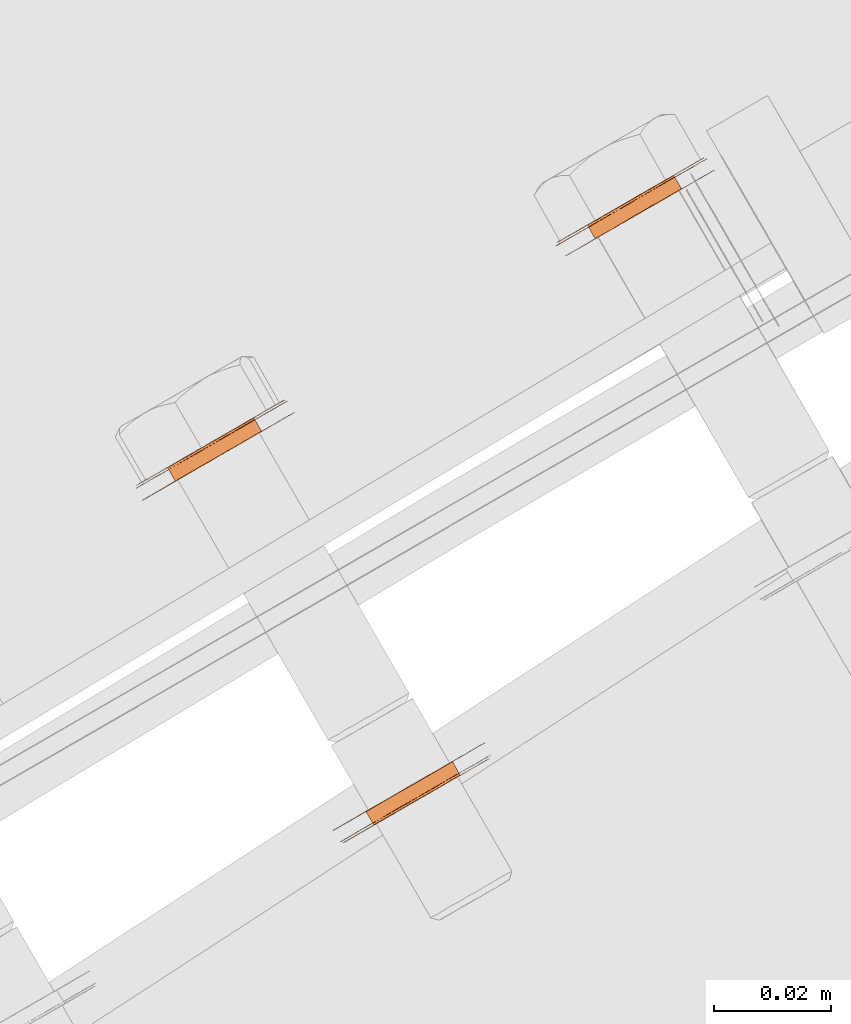
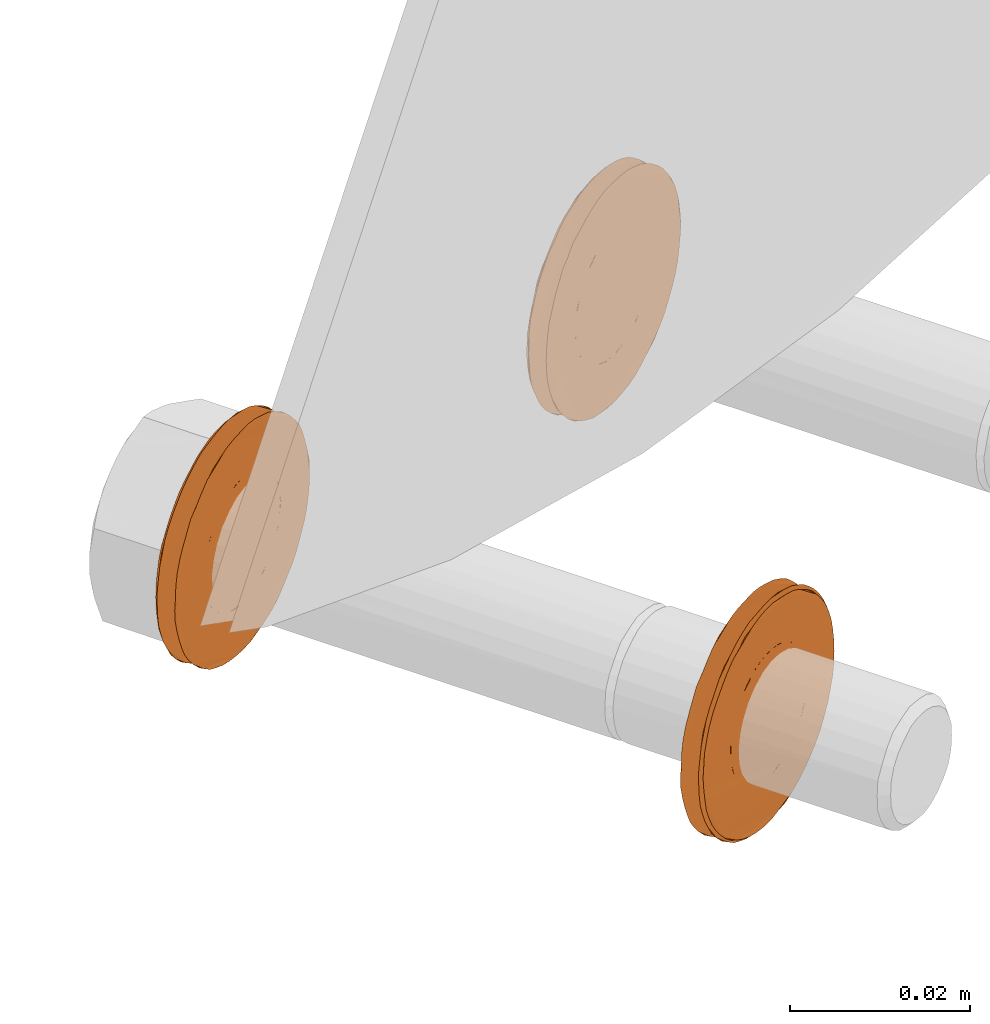
# One storey, part 113 of 126: 3 proxies.
"""IFC2X3 building model written with IfcOpenShell, lengths in millimetres."""

from ifc_helpers import new_model, si_unit, origin, origin_with_axes, place, context, project, spatial, faceted_brep, material, element, save


model = new_model("IFC2X3")

# Units and contexts
context_of_model_1 = context(None, 3, precision=0.1, world=origin())
context_of_model_2 = context(None, 3, precision=0.1, world=origin())
ifc_project = project(units=[si_unit("LENGTHUNIT", "METRE", prefix="MILLI"), si_unit("AREAUNIT", "SQUARE_METRE", prefix="CENTI"), si_unit("VOLUMEUNIT", "CUBIC_METRE", prefix="CENTI"), si_unit("MASSUNIT", "GRAM", prefix="KILO")], contexts=[context_of_model_1, context_of_model_2])

# Site, building, storey
site_placement = place(None, origin_with_axes())
site = spatial("IfcSite", under=ifc_project, at=site_placement, CompositionType="ELEMENT")
building_placement = place(site_placement, origin_with_axes())
building = spatial("IfcBuilding", under=site, at=building_placement, CompositionType="ELEMENT")
storey_placement = place(building_placement, origin_with_axes())
storey = spatial("IfcBuildingStorey", under=building, at=storey_placement, CompositionType="ELEMENT")

# Proxies
ifc_material = material(Name="STAHL")
proxy_1_placement = place(storey_placement, origin_with_axes())
element("IfcBuildingElementProxy", 1, at=proxy_1_placement, inside=storey, material=ifc_material, Name="profile", context=context_of_model_2, shape_type="Brep", body=[
    faceted_brep([(3949.6, 14948.2, 476.4), (3950.9, 14945.9, 476.4), (3949.9, 14945.3, 476.6), (3948.5, 14947.6, 476.6), (3946.7, 14946.5, 459.7), (3945.7, 14946.0, 460.1), (3947.1, 14943.6, 460.1), (3948.1, 14944.2, 459.7), (3944.7, 14945.4, 460.5), (3946.1, 14943.1, 460.5), (3943.8, 14944.9, 461.2), (3945.2, 14942.6, 461.2), (3943.0, 14944.4, 462.0), (3944.4, 14942.1, 462.0), (3942.3, 14944.0, 462.9), (3943.7, 14941.7, 462.9), (3941.8, 14943.7, 463.9), (3943.1, 14941.3, 463.9), (3941.3, 14943.4, 465.0), (3942.6, 14941.1, 465.0), (3941.0, 14943.2, 466.1), (3942.3, 14940.9, 466.1), (3940.8, 14943.1, 467.3), (3942.2, 14940.8, 467.3), (3940.8, 14943.1, 468.5), (3942.1, 14940.8, 468.5), (3940.9, 14943.2, 469.7), (3942.3, 14940.9, 469.7), (3941.2, 14943.4, 470.9), (3942.6, 14941.0, 470.9), (3941.6, 14943.6, 472.0), (3943.0, 14941.3, 472.0), (3942.2, 14943.9, 473.0), (3943.5, 14941.6, 473.0), (3942.9, 14944.3, 474.0), (3944.2, 14942.0, 474.0), (3943.6, 14944.8, 474.8), (3945.0, 14942.4, 474.8), (3944.5, 14945.3, 475.5), (3945.9, 14942.9, 475.5), (3945.5, 14945.8, 476.0), (3946.8, 14943.5, 476.0), (3946.5, 14946.4, 476.3), (3947.8, 14944.1, 476.3), (3947.5, 14947.0, 476.5), (3948.8, 14944.7, 476.5), (3936.5, 14937.5, 467.9), (3936.6, 14937.6, 469.4), (3936.8, 14937.7, 471.0), (3937.1, 14937.9, 472.5), (3937.6, 14938.1, 474.0), (3938.2, 14938.5, 475.4), (3938.9, 14938.9, 476.7), (3939.7, 14939.4, 478.0), (3940.7, 14939.9, 479.1), (3941.7, 14940.6, 480.1), (3940.6, 14942.5, 480.1), (3939.5, 14941.9, 479.1), (3938.6, 14941.4, 478.0), (3937.7, 14940.9, 476.7), (3937.0, 14940.5, 475.4), (3936.4, 14940.1, 474.0), (3935.9, 14939.9, 472.5), (3935.6, 14939.7, 471.0), (3935.4, 14939.6, 469.4), (3935.4, 14939.5, 467.9), (3935.4, 14939.6, 466.3), (3935.7, 14939.7, 464.8), (3936.0, 14939.9, 463.2), (3936.6, 14940.2, 461.8), (3937.2, 14940.6, 460.4), (3937.9, 14941.0, 459.1), (3938.8, 14941.5, 457.9), (3939.8, 14942.1, 456.8), (3940.9, 14942.7, 455.8), (3942.0, 14943.4, 455.0), (3943.2, 14944.1, 454.3), (3944.5, 14944.8, 453.7), (3945.8, 14945.6, 453.4), (3947.2, 14946.3, 453.1), (3948.5, 14947.1, 453.1), (3949.9, 14947.9, 453.2), (3951.2, 14948.7, 453.4), (3952.5, 14949.4, 453.9), (3953.8, 14950.2, 454.4), (3955.0, 14950.9, 455.2), (3956.1, 14951.5, 456.1), (3957.2, 14952.1, 457.1), (3958.1, 14952.7, 458.2), (3959.0, 14953.2, 459.4), (3959.7, 14953.6, 460.7), (3960.3, 14953.9, 462.1), (3960.8, 14954.2, 463.6), (3961.1, 14954.4, 465.1), (3961.3, 14954.5, 466.7), (3961.3, 14954.5, 468.3), (3961.2, 14954.5, 469.8), (3961.0, 14954.3, 471.4), (3960.7, 14954.1, 472.9), (3960.1, 14953.8, 474.4), (3959.5, 14953.5, 475.7), (3958.8, 14953.0, 477.0), (3957.9, 14952.5, 478.3), (3956.9, 14952.0, 479.3), (3955.8, 14951.4, 480.3), (3954.7, 14950.7, 481.2), (3953.5, 14950.0, 481.9), (3952.2, 14949.3, 482.4), (3950.9, 14948.5, 482.8), (3949.5, 14947.7, 483.0), (3948.2, 14946.9, 483.1), (3946.8, 14946.1, 483.0), (3945.5, 14945.4, 482.7), (3944.2, 14944.6, 482.3), (3942.9, 14943.9, 481.7), (3941.7, 14943.2, 481.0), (3942.9, 14941.2, 481.0), (3944.1, 14941.9, 481.7), (3945.3, 14942.6, 482.3), (3946.6, 14943.4, 482.7), (3948.0, 14944.2, 483.0), (3949.3, 14944.9, 483.1), (3950.7, 14945.7, 483.0), (3952.0, 14946.5, 482.8), (3953.4, 14947.3, 482.4), (3954.6, 14948.0, 481.9), (3955.8, 14948.7, 481.2), (3957.0, 14949.4, 480.3), (3958.1, 14950.0, 479.3), (3959.0, 14950.5, 478.3), (3959.9, 14951.0, 477.0), (3960.7, 14951.5, 475.7), (3961.3, 14951.8, 474.4), (3961.8, 14952.1, 472.9), (3962.2, 14952.4, 471.4), (3962.4, 14952.5, 469.8), (3962.5, 14952.5, 468.3), (3962.4, 14952.5, 466.7), (3962.2, 14952.4, 465.1), (3961.9, 14952.2, 463.6), (3961.4, 14951.9, 462.1), (3960.8, 14951.6, 460.7), (3960.1, 14951.2, 459.4), (3959.3, 14950.7, 458.2), (3958.3, 14950.1, 457.1), (3957.3, 14949.5, 456.1), (3956.1, 14948.9, 455.2), (3954.9, 14948.2, 454.4), (3953.7, 14947.4, 453.9), (3952.4, 14946.7, 453.4), (3951.0, 14945.9, 453.2), (3949.7, 14945.1, 453.1), (3948.3, 14944.4, 453.1), (3947.0, 14943.6, 453.4), (3945.6, 14942.8, 453.7), (3944.4, 14942.1, 454.3), (3943.2, 14941.4, 455.0), (3942.0, 14940.7, 455.8), (3940.9, 14940.1, 456.8), (3940.0, 14939.5, 457.9), (3939.1, 14939.0, 459.1), (3938.3, 14938.6, 460.4), (3937.7, 14938.2, 461.8), (3937.2, 14937.9, 463.2), (3936.8, 14937.7, 464.8), (3936.6, 14937.6, 466.3), (3959.2, 14953.8, 475.2), (3958.5, 14953.3, 476.5), (3957.6, 14952.8, 477.7), (3956.7, 14952.3, 478.9), (3955.6, 14951.7, 479.9), (3954.4, 14951.0, 480.7), (3953.2, 14950.3, 481.4), (3951.9, 14949.6, 482.0), (3950.6, 14948.8, 482.4), (3949.3, 14948.0, 482.6), (3947.9, 14947.2, 482.7), (3946.5, 14946.4, 482.5), (3945.2, 14945.7, 482.3), (3943.9, 14944.9, 481.8), (3942.6, 14944.2, 481.2), (3941.4, 14943.5, 480.4), (3940.3, 14942.8, 479.5), (3939.3, 14942.2, 478.5), (3938.3, 14941.7, 477.3), (3937.5, 14941.3, 476.0), (3936.9, 14940.9, 474.6), (3936.3, 14940.5, 473.2), (3935.9, 14940.3, 471.7), (3935.6, 14940.2, 470.1), (3935.5, 14940.1, 468.6), (3935.5, 14940.1, 467.0), (3935.7, 14940.2, 465.4), (3936.0, 14940.4, 463.9), (3936.5, 14940.7, 462.4), (3937.1, 14941.0, 461.0), (3937.8, 14941.4, 459.6), (3938.7, 14941.9, 458.4), (3939.6, 14942.5, 457.3), (3940.7, 14943.1, 456.3), (3941.9, 14943.7, 455.4), (3943.1, 14944.4, 454.7), (3944.4, 14945.2, 454.1), (3945.7, 14946.0, 453.8), (3947.0, 14946.7, 453.5), (3948.4, 14947.5, 453.5), (3949.8, 14948.3, 453.6), (3951.1, 14949.1, 453.9), (3952.4, 14949.8, 454.3), (3953.7, 14950.6, 454.9), (3954.9, 14951.3, 455.7), (3956.0, 14951.9, 456.6), (3957.0, 14952.5, 457.7), (3958.0, 14953.0, 458.8), (3958.8, 14953.5, 460.1), (3959.4, 14953.9, 461.5), (3960.0, 14954.2, 462.9), (3960.4, 14954.4, 464.5), (3960.7, 14954.6, 466.0), (3960.8, 14954.7, 467.6), (3960.8, 14954.7, 469.2), (3960.6, 14954.6, 470.7), (3960.3, 14954.4, 472.3), (3959.8, 14954.1, 473.7), (3954.5, 14951.1, 472.3), (3954.0, 14950.7, 473.3), (3953.3, 14950.3, 474.2), (3952.5, 14949.9, 475.0), (3951.6, 14949.3, 475.6), (3950.6, 14948.8, 476.1), (3947.8, 14947.1, 459.6), (3948.8, 14947.8, 459.6), (3949.8, 14948.4, 459.8), (3950.8, 14948.9, 460.2), (3951.8, 14949.5, 460.7), (3952.7, 14950.0, 461.4), (3953.4, 14950.4, 462.2), (3954.1, 14950.8, 463.1), (3954.7, 14951.1, 464.1), (3955.1, 14951.4, 465.2), (3955.4, 14951.5, 466.4), (3955.5, 14951.6, 467.6), (3955.5, 14951.6, 468.8), (3955.3, 14951.5, 470.0), (3955.0, 14951.3, 471.2), (3950.2, 14945.4, 459.6), (3951.2, 14946.0, 459.8), (3951.9, 14946.5, 476.1), (3949.1, 14944.8, 459.6), (3952.9, 14947.0, 475.6), (3953.8, 14947.5, 475.0), (3954.6, 14948.0, 474.2), (3955.3, 14948.4, 473.3), (3955.9, 14948.7, 472.3), (3956.3, 14949.0, 471.2), (3956.7, 14949.2, 470.0), (3956.8, 14949.3, 468.8), (3956.8, 14949.3, 467.6), (3956.7, 14949.2, 466.4), (3956.4, 14949.0, 465.2), (3956.0, 14948.8, 464.1), (3955.5, 14948.5, 463.1), (3954.8, 14948.1, 462.2), (3954.0, 14947.6, 461.4), (3953.1, 14947.1, 460.7), (3952.2, 14946.6, 460.2)], [[[0, 1, 2, 3]], [[4, 5, 6, 7]], [[5, 8, 9, 6]], [[8, 10, 11, 9]], [[10, 12, 13, 11]], [[12, 14, 15, 13]], [[14, 16, 17, 15]], [[16, 18, 19, 17]], [[18, 20, 21, 19]], [[20, 22, 23, 21]], [[22, 24, 25, 23]], [[24, 26, 27, 25]], [[26, 28, 29, 27]], [[28, 30, 31, 29]], [[30, 32, 33, 31]], [[32, 34, 35, 33]], [[34, 36, 37, 35]], [[36, 38, 39, 37]], [[38, 40, 41, 39]], [[40, 42, 43, 41]], [[42, 44, 45, 43]], [[44, 3, 2, 45]], [[46, 47, 48, 49, 50, 51, 52, 53, 54, 55, 56, 57, 58, 59, 60, 61, 62, 63, 64, 65, 66, 67, 68, 69, 70, 71, 72, 73, 74, 75, 76, 77, 78, 79, 80, 81, 82, 83, 84, 85, 86, 87, 88, 89, 90, 91, 92, 93, 94, 95, 96, 97, 98, 99, 100, 101, 102, 103, 104, 105, 106, 107, 108, 109, 110, 111, 112, 113, 114, 115, 56, 55, 116, 117, 118, 119, 120, 121, 122, 123, 124, 125, 126, 127, 128, 129, 130, 131, 132, 133, 134, 135, 136, 137, 138, 139, 140, 141, 142, 143, 144, 145, 146, 147, 148, 149, 150, 151, 152, 153, 154, 155, 156, 157, 158, 159, 160, 161, 162, 163, 164, 165]], [[65, 64, 63, 62, 61, 60, 59, 58, 57, 56, 115, 114, 113, 112, 111, 110, 109, 108, 107, 106, 105, 104, 103, 102, 101, 100, 166, 167, 168, 169, 170, 171, 172, 173, 174, 175, 176, 177, 178, 179, 180, 181, 182, 183, 184, 185, 186, 187, 188, 189, 190, 191, 192, 193, 194, 195, 196, 197, 198, 199, 200, 201, 202, 203, 204, 205, 206, 207, 208, 209, 210, 211, 212, 213, 214, 215, 216, 217, 218, 219, 220, 221, 222, 223, 166, 100, 99, 98, 97, 96, 95, 94, 93, 92, 91, 90, 89, 88, 87, 86, 85, 84, 83, 82, 81, 80, 79, 78, 77, 76, 75, 74, 73, 72, 71, 70, 69, 68, 67, 66]], [[190, 189, 188, 187, 186, 185, 184, 183, 182, 181, 180, 179, 178, 177, 176, 175, 174, 173, 172, 171, 170, 169, 168, 167, 166, 223, 224, 225, 226, 227, 228, 229, 0, 3, 44, 42, 40, 38, 36, 34, 32, 30, 28, 26, 24, 22, 20, 18, 16, 14, 12, 10, 8, 5, 4, 230, 231, 232, 233, 234, 235, 236, 237, 238, 239, 240, 241, 242, 243, 244, 224, 223, 222, 221, 220, 219, 218, 217, 216, 215, 214, 213, 212, 211, 210, 209, 208, 207, 206, 205, 204, 203, 202, 201, 200, 199, 198, 197, 196, 195, 194, 193, 192, 191]], [[231, 245, 246, 232]], [[0, 229, 247, 1]], [[230, 248, 245, 231]], [[4, 7, 248, 230]], [[228, 249, 247, 229]], [[227, 250, 249, 228]], [[226, 251, 250, 227]], [[225, 252, 251, 226]], [[224, 253, 252, 225]], [[244, 254, 253, 224]], [[243, 255, 254, 244]], [[242, 256, 255, 243]], [[241, 257, 256, 242]], [[240, 258, 257, 241]], [[239, 259, 258, 240]], [[238, 260, 259, 239]], [[237, 261, 260, 238]], [[236, 262, 261, 237]], [[235, 263, 262, 236]], [[234, 264, 263, 235]], [[233, 265, 264, 234]], [[232, 246, 265, 233]], [[46, 165, 164, 163, 162, 161, 160, 159, 158, 157, 156, 155, 154, 153, 152, 151, 150, 149, 148, 147, 146, 145, 144, 143, 142, 141, 140, 139, 138, 137, 136, 135, 134, 133, 132, 131, 130, 253, 254, 255, 256, 257, 258, 259, 260, 261, 262, 263, 264, 265, 246, 245, 248, 7, 6, 9, 11, 13, 15, 17, 19, 21, 23, 25, 27, 29, 31, 33, 35, 37, 39, 41, 43, 45, 2, 1, 247, 249, 250, 251, 252, 253, 130, 129, 128, 127, 126, 125, 124, 123, 122, 121, 120, 119, 118, 117, 116, 55, 54, 53, 52, 51, 50, 49, 48, 47]]]),
])
proxy_2_placement = place(storey_placement, origin_with_axes())
element("IfcBuildingElementProxy", 2, at=proxy_2_placement, inside=storey, material=ifc_material, Name="profile", context=context_of_model_2, shape_type="Brep", body=[
    faceted_brep([(3914.6, 14846.7, 492.4), (3913.2, 14849.0, 492.4), (3914.2, 14849.6, 491.8), (3915.5, 14847.2, 491.8), (3908.9, 14843.4, 476.7), (3909.9, 14844.0, 476.3), (3908.6, 14846.4, 476.3), (3907.6, 14845.8, 476.7), (3911.0, 14844.6, 476.1), (3909.6, 14847.0, 476.1), (3912.0, 14845.2, 476.0), (3910.7, 14847.6, 476.0), (3913.1, 14845.8, 476.2), (3911.7, 14848.2, 476.2), (3914.1, 14846.4, 476.5), (3912.7, 14848.8, 476.5), (3915.0, 14847.0, 476.9), (3913.7, 14849.3, 476.9), (3915.9, 14847.5, 477.5), (3914.6, 14849.8, 477.5), (3916.8, 14848.0, 478.3), (3915.4, 14850.3, 478.3), (3917.5, 14848.4, 479.2), (3916.1, 14850.7, 479.2), (3918.1, 14848.7, 480.2), (3916.7, 14851.1, 480.2), (3918.6, 14849.0, 481.3), (3917.2, 14851.3, 481.3), (3918.9, 14849.2, 482.4), (3917.5, 14851.5, 482.4), (3919.1, 14849.3, 483.6), (3917.7, 14851.6, 483.6), (3919.1, 14849.3, 484.8), (3917.8, 14851.7, 484.8), (3919.0, 14849.3, 486.0), (3917.6, 14851.6, 486.0), (3918.7, 14849.1, 487.2), (3917.4, 14851.4, 487.2), (3918.3, 14848.9, 488.3), (3917.0, 14851.2, 488.3), (3917.8, 14848.6, 489.4), (3916.4, 14850.9, 489.4), (3917.1, 14848.2, 490.3), (3915.8, 14850.5, 490.3), (3916.4, 14847.7, 491.1), (3915.0, 14850.1, 491.1), (3898.6, 14837.9, 484.1), (3898.6, 14837.9, 485.7), (3898.8, 14838.0, 487.2), (3899.1, 14838.2, 488.8), (3899.5, 14838.5, 490.3), (3900.1, 14838.8, 491.7), (3900.8, 14839.2, 493.0), (3901.7, 14839.7, 494.3), (3902.6, 14840.3, 495.4), (3903.6, 14840.9, 496.4), (3904.8, 14841.5, 497.3), (3906.0, 14842.2, 498.1), (3907.2, 14842.9, 498.7), (3908.5, 14843.7, 499.1), (3909.9, 14844.4, 499.4), (3911.2, 14845.2, 499.5), (3912.6, 14846.0, 499.5), (3913.9, 14846.8, 499.3), (3915.2, 14847.5, 498.9), (3916.5, 14848.3, 498.4), (3917.7, 14849.0, 497.7), (3918.9, 14849.7, 496.9), (3920.0, 14850.3, 495.9), (3921.0, 14850.9, 494.8), (3921.9, 14851.4, 493.6), (3922.6, 14851.8, 492.4), (3923.3, 14852.2, 491.0), (3923.8, 14852.5, 489.5), (3924.2, 14852.7, 488.0), (3924.4, 14852.9, 486.5), (3924.5, 14852.9, 484.9), (3923.4, 14854.9, 483.3), (3923.4, 14854.9, 484.9), (3923.3, 14854.8, 486.5), (3923.0, 14854.7, 488.0), (3922.6, 14854.5, 489.5), (3922.1, 14854.2, 491.0), (3921.5, 14853.8, 492.4), (3920.7, 14853.4, 493.6), (3919.8, 14852.8, 494.8), (3918.8, 14852.3, 495.9), (3917.8, 14851.7, 496.9), (3916.6, 14851.0, 497.7), (3915.4, 14850.3, 498.4), (3914.1, 14849.5, 498.9), (3912.8, 14848.8, 499.3), (3911.4, 14848.0, 499.5), (3910.1, 14847.2, 499.5), (3908.7, 14846.4, 499.4), (3907.4, 14845.7, 499.1), (3906.1, 14844.9, 498.7), (3904.8, 14844.2, 498.1), (3903.6, 14843.5, 497.3), (3902.5, 14842.8, 496.4), (3901.5, 14842.2, 495.4), (3900.5, 14841.7, 494.3), (3899.7, 14841.2, 493.0), (3899.0, 14840.8, 491.7), (3898.4, 14840.5, 490.3), (3897.9, 14840.2, 488.8), (3897.6, 14840.0, 487.2), (3897.5, 14839.9, 485.7), (3897.4, 14839.9, 484.1), (3897.5, 14840.0, 482.6), (3897.8, 14840.1, 481.0), (3898.2, 14840.3, 479.5), (3898.7, 14840.6, 478.1), (3899.3, 14841.0, 476.7), (3900.1, 14841.5, 475.4), (3901.0, 14842.0, 474.2), (3902.0, 14842.5, 473.1), (3903.0, 14843.2, 472.2), (3904.2, 14843.8, 471.3), (3905.4, 14844.5, 470.7), (3906.7, 14845.3, 470.1), (3908.0, 14846.0, 469.8), (3909.4, 14846.8, 469.6), (3910.7, 14847.6, 469.5), (3912.1, 14848.4, 469.6), (3913.4, 14849.2, 469.9), (3914.7, 14849.9, 470.4), (3916.0, 14850.6, 471.0), (3917.2, 14851.3, 471.7), (3918.3, 14852.0, 472.6), (3919.3, 14852.6, 473.6), (3920.3, 14853.1, 474.8), (3921.1, 14853.6, 476.0), (3921.8, 14854.0, 477.4), (3922.4, 14854.3, 478.8), (3922.9, 14854.6, 480.3), (3923.2, 14854.8, 481.8), (3924.5, 14852.9, 483.3), (3924.3, 14852.8, 481.8), (3924.0, 14852.6, 480.3), (3923.6, 14852.3, 478.8), (3923.0, 14852.0, 477.4), (3922.3, 14851.6, 476.0), (3921.4, 14851.1, 474.8), (3920.5, 14850.6, 473.6), (3919.5, 14850.0, 472.6), (3918.3, 14849.3, 471.7), (3917.1, 14848.6, 471.0), (3915.9, 14847.9, 470.4), (3914.6, 14847.2, 469.9), (3913.2, 14846.4, 469.6), (3911.9, 14845.6, 469.5), (3910.5, 14844.8, 469.6), (3909.2, 14844.1, 469.8), (3907.9, 14843.3, 470.1), (3906.6, 14842.5, 470.7), (3905.4, 14841.8, 471.3), (3904.2, 14841.2, 472.2), (3903.1, 14840.5, 473.1), (3902.1, 14840.0, 474.2), (3901.2, 14839.5, 475.4), (3900.5, 14839.0, 476.7), (3899.8, 14838.6, 478.1), (3899.3, 14838.3, 479.5), (3898.9, 14838.1, 481.0), (3898.7, 14838.0, 482.6), (3899.1, 14837.8, 484.7), (3899.2, 14837.8, 486.3), (3899.4, 14838.0, 487.8), (3899.8, 14838.2, 489.4), (3900.3, 14838.5, 490.8), (3901.0, 14838.9, 492.2), (3901.8, 14839.3, 493.5), (3902.7, 14839.8, 494.7), (3903.7, 14840.4, 495.8), (3904.8, 14841.1, 496.7), (3906.0, 14841.7, 497.5), (3907.2, 14842.5, 498.2), (3908.5, 14843.2, 498.6), (3909.9, 14844.0, 499.0), (3911.2, 14844.8, 499.1), (3912.6, 14845.6, 499.1), (3914.0, 14846.3, 498.9), (3915.3, 14847.1, 498.5), (3916.6, 14847.9, 498.0), (3917.8, 14848.6, 497.3), (3919.0, 14849.2, 496.5), (3920.1, 14849.9, 495.5), (3921.0, 14850.4, 494.4), (3921.9, 14850.9, 493.2), (3922.7, 14851.4, 491.9), (3923.3, 14851.7, 490.5), (3923.8, 14852.0, 489.0), (3924.1, 14852.2, 487.5), (3924.3, 14852.3, 485.9), (3924.4, 14852.4, 484.3), (3924.3, 14852.3, 482.7), (3924.1, 14852.2, 481.2), (3923.7, 14852.0, 479.7), (3923.2, 14851.7, 478.2), (3922.5, 14851.3, 476.8), (3921.7, 14850.8, 475.5), (3920.8, 14850.3, 474.3), (3919.8, 14849.7, 473.3), (3918.7, 14849.1, 472.3), (3917.5, 14848.4, 471.5), (3916.3, 14847.7, 470.9), (3915.0, 14846.9, 470.4), (3913.6, 14846.2, 470.1), (3912.3, 14845.4, 469.9), (3910.9, 14844.6, 469.9), (3909.5, 14843.8, 470.1), (3908.2, 14843.0, 470.5), (3906.9, 14842.3, 471.0), (3905.7, 14841.6, 471.7), (3904.5, 14840.9, 472.5), (3903.4, 14840.3, 473.5), (3902.5, 14839.7, 474.6), (3901.6, 14839.2, 475.8), (3900.8, 14838.8, 477.2), (3900.2, 14838.4, 478.6), (3899.7, 14838.1, 480.0), (3899.4, 14837.9, 481.6), (3899.2, 14837.8, 483.1), (3908.5, 14843.2, 492.1), (3909.4, 14843.7, 492.6), (3910.4, 14844.3, 492.9), (3911.5, 14844.9, 493.0), (3912.5, 14845.5, 493.0), (3913.6, 14846.1, 492.8), (3908.0, 14842.9, 477.2), (3907.1, 14842.4, 477.9), (3906.4, 14842.0, 478.7), (3905.7, 14841.6, 479.7), (3905.2, 14841.3, 480.7), (3904.8, 14841.0, 481.8), (3904.5, 14840.9, 483.0), (3904.4, 14840.8, 484.2), (3904.4, 14840.8, 485.4), (3904.6, 14841.0, 486.6), (3904.9, 14841.1, 487.8), (3905.4, 14841.4, 488.9), (3906.0, 14841.8, 489.8), (3906.7, 14842.2, 490.7), (3907.6, 14842.6, 491.5), (3906.6, 14845.2, 477.2), (3912.2, 14848.5, 492.8), (3911.2, 14847.9, 493.0), (3910.1, 14847.3, 493.0), (3909.1, 14846.7, 492.9), (3908.1, 14846.1, 492.6), (3907.1, 14845.5, 492.1), (3906.2, 14845.0, 491.5), (3905.4, 14844.5, 490.7), (3904.7, 14844.1, 489.8), (3904.1, 14843.8, 488.9), (3903.6, 14843.5, 487.8), (3903.3, 14843.3, 486.6), (3903.1, 14843.2, 485.4), (3903.0, 14843.2, 484.2), (3903.2, 14843.2, 483.0), (3903.4, 14843.4, 481.8), (3903.8, 14843.6, 480.7), (3904.4, 14843.9, 479.7), (3905.0, 14844.3, 478.7), (3905.8, 14844.7, 477.9)], [[[0, 1, 2, 3]], [[4, 5, 6, 7]], [[5, 8, 9, 6]], [[8, 10, 11, 9]], [[10, 12, 13, 11]], [[12, 14, 15, 13]], [[14, 16, 17, 15]], [[16, 18, 19, 17]], [[18, 20, 21, 19]], [[20, 22, 23, 21]], [[22, 24, 25, 23]], [[24, 26, 27, 25]], [[26, 28, 29, 27]], [[28, 30, 31, 29]], [[30, 32, 33, 31]], [[32, 34, 35, 33]], [[34, 36, 37, 35]], [[36, 38, 39, 37]], [[38, 40, 41, 39]], [[40, 42, 43, 41]], [[42, 44, 45, 43]], [[44, 3, 2, 45]], [[46, 47, 48, 49, 50, 51, 52, 53, 54, 55, 56, 57, 58, 59, 60, 61, 62, 63, 64, 65, 66, 67, 68, 69, 70, 71, 72, 73, 74, 75, 76, 77, 78, 79, 80, 81, 82, 83, 84, 85, 86, 87, 88, 89, 90, 91, 92, 93, 94, 95, 96, 97, 98, 99, 100, 101, 102, 103, 104, 105, 106, 107, 108, 109, 110, 111, 112, 113, 114, 115, 116, 117, 118, 119, 120, 121, 122, 123, 124, 125, 126, 127, 128, 129, 130, 131, 132, 133, 134, 135, 136, 77, 76, 137, 138, 139, 140, 141, 142, 143, 144, 145, 146, 147, 148, 149, 150, 151, 152, 153, 154, 155, 156, 157, 158, 159, 160, 161, 162, 163, 164, 165]], [[166, 167, 168, 169, 170, 171, 172, 173, 174, 175, 176, 177, 58, 57, 56, 55, 54, 53, 52, 51, 50, 49, 48, 47, 46, 165, 164, 163, 162, 161, 160, 159, 158, 157, 156, 155, 154, 153, 152, 151, 150, 149, 148, 147, 146, 145, 144, 143, 142, 141, 140, 139, 138, 137, 76, 75, 74, 73, 72, 71, 70, 69, 68, 67, 66, 65, 64, 63, 62, 61, 60, 59, 58, 177, 178, 179, 180, 181, 182, 183, 184, 185, 186, 187, 188, 189, 190, 191, 192, 193, 194, 195, 196, 197, 198, 199, 200, 201, 202, 203, 204, 205, 206, 207, 208, 209, 210, 211, 212, 213, 214, 215, 216, 217, 218, 219, 220, 221, 222, 223]], [[166, 223, 222, 221, 220, 219, 218, 217, 216, 215, 214, 213, 212, 211, 210, 209, 208, 207, 206, 205, 204, 203, 202, 201, 200, 199, 198, 197, 196, 195, 194, 193, 192, 191, 190, 189, 188, 187, 186, 185, 184, 183, 182, 181, 180, 179, 178, 177, 176, 175, 224, 225, 226, 227, 228, 229, 0, 3, 44, 42, 40, 38, 36, 34, 32, 30, 28, 26, 24, 22, 20, 18, 16, 14, 12, 10, 8, 5, 4, 230, 231, 232, 233, 234, 235, 236, 237, 238, 239, 240, 241, 242, 243, 244, 224, 175, 174, 173, 172, 171, 170, 169, 168, 167]], [[230, 4, 7, 245]], [[229, 246, 1, 0]], [[229, 228, 247, 246]], [[228, 227, 248, 247]], [[227, 226, 249, 248]], [[226, 225, 250, 249]], [[225, 224, 251, 250]], [[224, 244, 252, 251]], [[244, 243, 253, 252]], [[243, 242, 254, 253]], [[242, 241, 255, 254]], [[241, 240, 256, 255]], [[240, 239, 257, 256]], [[239, 238, 258, 257]], [[238, 237, 259, 258]], [[237, 236, 260, 259]], [[236, 235, 261, 260]], [[235, 234, 262, 261]], [[234, 233, 263, 262]], [[233, 232, 264, 263]], [[232, 231, 265, 264]], [[231, 230, 245, 265]], [[108, 107, 106, 105, 104, 103, 102, 101, 100, 99, 98, 97, 96, 95, 250, 251, 252, 253, 254, 255, 256, 257, 258, 259, 260, 261, 262, 263, 264, 265, 245, 7, 6, 9, 11, 13, 15, 17, 19, 21, 23, 25, 27, 29, 31, 33, 35, 37, 39, 41, 43, 45, 2, 1, 246, 247, 248, 249, 250, 95, 94, 93, 92, 91, 90, 89, 88, 87, 86, 85, 84, 83, 82, 81, 80, 79, 78, 77, 136, 135, 134, 133, 132, 131, 130, 129, 128, 127, 126, 125, 124, 123, 122, 121, 120, 119, 118, 117, 116, 115, 114, 113, 112, 111, 110, 109]]]),
])
proxy_3_placement = place(storey_placement, origin_with_axes())
element("IfcBuildingElementProxy", 3, at=proxy_3_placement, inside=storey, material=ifc_material, Name="profile", context=context_of_model_2, shape_type="Brep", body=[
    faceted_brep([(3879.4, 14907.7, 492.4), (3880.7, 14905.3, 492.4), (3879.7, 14904.8, 492.8), (3878.4, 14907.1, 492.8), (3873.7, 14904.4, 476.7), (3872.8, 14903.9, 477.2), (3874.1, 14901.5, 477.2), (3875.1, 14902.1, 476.7), (3871.9, 14903.4, 477.9), (3873.3, 14901.0, 477.9), (3871.2, 14902.9, 478.7), (3872.5, 14900.6, 478.7), (3870.5, 14902.5, 479.7), (3871.9, 14900.2, 479.7), (3870.0, 14902.2, 480.7), (3871.3, 14899.9, 480.7), (3869.6, 14902.0, 481.8), (3870.9, 14899.7, 481.8), (3869.3, 14901.9, 483.0), (3870.7, 14899.5, 483.0), (3869.2, 14901.8, 484.2), (3870.5, 14899.5, 484.2), (3869.2, 14901.8, 485.4), (3870.6, 14899.5, 485.4), (3869.4, 14901.9, 486.6), (3870.8, 14899.6, 486.6), (3869.7, 14902.1, 487.8), (3871.1, 14899.8, 487.8), (3870.2, 14902.4, 488.9), (3871.6, 14900.0, 488.9), (3870.8, 14902.7, 489.8), (3872.2, 14900.4, 489.8), (3871.5, 14903.1, 490.7), (3872.9, 14900.8, 490.7), (3872.4, 14903.6, 491.5), (3873.7, 14901.3, 491.5), (3873.3, 14904.1, 492.1), (3874.6, 14901.8, 492.1), (3874.2, 14904.7, 492.6), (3875.6, 14902.4, 492.6), (3875.2, 14905.3, 492.9), (3876.6, 14902.9, 492.9), (3876.3, 14905.9, 493.0), (3877.6, 14903.5, 493.0), (3877.3, 14906.5, 493.0), (3878.7, 14904.2, 493.0), (3864.9, 14896.2, 484.1), (3865.0, 14896.2, 485.7), (3865.1, 14896.3, 487.2), (3865.4, 14896.5, 488.8), (3865.9, 14896.8, 490.3), (3866.5, 14897.1, 491.7), (3867.2, 14897.5, 493.0), (3868.0, 14898.0, 494.3), (3869.0, 14898.5, 495.4), (3868.8, 14901.1, 496.4), (3867.8, 14900.5, 495.4), (3866.9, 14900.0, 494.3), (3866.0, 14899.5, 493.0), (3865.3, 14899.1, 491.7), (3864.7, 14898.8, 490.3), (3864.3, 14898.5, 488.8), (3864.0, 14898.3, 487.2), (3863.8, 14898.2, 485.7), (3863.8, 14898.2, 484.1), (3863.9, 14898.3, 482.6), (3864.1, 14898.4, 481.0), (3864.5, 14898.6, 479.5), (3865.0, 14898.9, 478.1), (3865.7, 14899.3, 476.7), (3866.4, 14899.7, 475.4), (3867.3, 14900.3, 474.2), (3868.3, 14900.8, 473.1), (3869.4, 14901.4, 472.2), (3870.6, 14902.1, 471.3), (3871.8, 14902.8, 470.7), (3873.1, 14903.6, 470.1), (3874.4, 14904.3, 469.8), (3875.7, 14905.1, 469.6), (3877.1, 14905.9, 469.5), (3878.4, 14906.7, 469.6), (3879.8, 14907.4, 469.9), (3881.1, 14908.2, 470.4), (3882.3, 14908.9, 471.0), (3883.5, 14909.6, 471.7), (3884.7, 14910.3, 472.6), (3885.7, 14910.9, 473.6), (3886.6, 14911.4, 474.8), (3887.5, 14911.9, 476.0), (3888.2, 14912.3, 477.4), (3888.8, 14912.6, 478.8), (3889.2, 14912.9, 480.3), (3889.5, 14913.1, 481.8), (3889.7, 14913.2, 483.3), (3889.7, 14913.2, 484.9), (3889.6, 14913.1, 486.5), (3889.4, 14913.0, 488.0), (3889.0, 14912.8, 489.5), (3888.5, 14912.5, 491.0), (3887.8, 14912.1, 492.4), (3887.1, 14911.6, 493.6), (3886.2, 14911.1, 494.8), (3885.2, 14910.6, 495.9), (3884.1, 14909.9, 496.9), (3882.9, 14909.3, 497.7), (3881.7, 14908.6, 498.4), (3880.4, 14907.8, 498.9), (3879.1, 14907.1, 499.3), (3877.8, 14906.3, 499.5), (3876.4, 14905.5, 499.5), (3875.1, 14904.7, 499.4), (3873.7, 14903.9, 499.1), (3872.4, 14903.2, 498.7), (3871.2, 14902.5, 498.1), (3870.0, 14901.8, 497.3), (3870.0, 14899.1, 496.4), (3871.1, 14899.8, 497.3), (3872.3, 14900.5, 498.1), (3873.6, 14901.2, 498.7), (3874.9, 14902.0, 499.1), (3876.2, 14902.7, 499.4), (3877.6, 14903.5, 499.5), (3878.9, 14904.3, 499.5), (3880.3, 14905.1, 499.3), (3881.6, 14905.8, 498.9), (3882.9, 14906.6, 498.4), (3884.1, 14907.3, 497.7), (3885.3, 14907.9, 496.9), (3886.3, 14908.6, 495.9), (3887.3, 14909.1, 494.8), (3888.2, 14909.7, 493.6), (3889.0, 14910.1, 492.4), (3889.6, 14910.5, 491.0), (3890.1, 14910.8, 489.5), (3890.5, 14911.0, 488.0), (3890.8, 14911.1, 486.5), (3890.9, 14911.2, 484.9), (3890.9, 14911.2, 483.3), (3890.7, 14911.1, 481.8), (3890.4, 14910.9, 480.3), (3889.9, 14910.6, 478.8), (3889.3, 14910.3, 477.4), (3888.6, 14909.9, 476.0), (3887.8, 14909.4, 474.8), (3886.8, 14908.9, 473.6), (3885.8, 14908.3, 472.6), (3884.7, 14907.6, 471.7), (3883.5, 14906.9, 471.0), (3882.2, 14906.2, 470.4), (3880.9, 14905.5, 469.9), (3879.6, 14904.7, 469.6), (3878.2, 14903.9, 469.5), (3876.9, 14903.1, 469.6), (3875.5, 14902.3, 469.8), (3874.2, 14901.6, 470.1), (3872.9, 14900.8, 470.7), (3871.7, 14900.1, 471.3), (3870.5, 14899.5, 472.2), (3869.5, 14898.8, 473.1), (3868.5, 14898.3, 474.2), (3867.6, 14897.8, 475.4), (3866.8, 14897.3, 476.7), (3866.2, 14896.9, 478.1), (3865.7, 14896.6, 479.5), (3865.3, 14896.4, 481.0), (3865.0, 14896.3, 482.6), (3888.6, 14913.0, 489.0), (3888.1, 14912.7, 490.5), (3887.5, 14912.3, 491.9), (3886.7, 14911.9, 493.2), (3885.8, 14911.4, 494.4), (3884.9, 14910.8, 495.5), (3883.8, 14910.2, 496.5), (3882.6, 14909.5, 497.3), (3881.4, 14908.8, 498.0), (3880.1, 14908.1, 498.5), (3878.8, 14907.3, 498.9), (3877.4, 14906.5, 499.1), (3876.0, 14905.7, 499.1), (3874.7, 14905.0, 499.0), (3873.3, 14904.2, 498.6), (3872.0, 14903.4, 498.2), (3870.8, 14902.7, 497.5), (3869.6, 14902.0, 496.7), (3868.5, 14901.4, 495.8), (3867.5, 14900.8, 494.7), (3866.6, 14900.3, 493.5), (3865.8, 14899.8, 492.2), (3865.1, 14899.5, 490.8), (3864.6, 14899.2, 489.4), (3864.2, 14898.9, 487.8), (3864.0, 14898.8, 486.3), (3863.9, 14898.7, 484.7), (3864.0, 14898.8, 483.1), (3864.2, 14898.9, 481.6), (3864.5, 14899.1, 480.0), (3865.0, 14899.4, 478.6), (3865.6, 14899.7, 477.2), (3866.4, 14900.2, 475.8), (3867.3, 14900.7, 474.6), (3868.2, 14901.2, 473.5), (3869.3, 14901.9, 472.5), (3870.5, 14902.5, 471.7), (3871.7, 14903.2, 471.0), (3873.0, 14904.0, 470.5), (3874.3, 14904.8, 470.1), (3875.7, 14905.5, 469.9), (3877.1, 14906.3, 469.9), (3878.4, 14907.1, 470.1), (3879.8, 14907.9, 470.4), (3881.1, 14908.6, 470.9), (3882.3, 14909.4, 471.5), (3883.5, 14910.1, 472.3), (3884.6, 14910.7, 473.3), (3885.6, 14911.3, 474.3), (3886.5, 14911.8, 475.5), (3887.3, 14912.2, 476.8), (3888.0, 14912.6, 478.2), (3888.5, 14912.9, 479.7), (3888.9, 14913.1, 481.2), (3889.1, 14913.3, 482.7), (3889.2, 14913.3, 484.3), (3889.1, 14913.3, 485.9), (3888.9, 14913.2, 487.5), (3883.1, 14909.8, 488.3), (3882.6, 14909.5, 489.4), (3881.9, 14909.1, 490.3), (3881.2, 14908.7, 491.1), (3880.3, 14908.2, 491.8), (3874.7, 14905.0, 476.3), (3875.8, 14905.6, 476.1), (3876.8, 14906.2, 476.0), (3877.9, 14906.8, 476.2), (3878.9, 14907.4, 476.5), (3879.8, 14907.9, 476.9), (3880.7, 14908.5, 477.5), (3881.6, 14908.9, 478.3), (3882.3, 14909.3, 479.2), (3882.9, 14909.7, 480.2), (3883.4, 14910.0, 481.3), (3883.7, 14910.2, 482.4), (3883.9, 14910.3, 483.6), (3883.9, 14910.3, 484.8), (3883.8, 14910.2, 486.0), (3883.5, 14910.1, 487.2), (3876.1, 14902.6, 476.3), (3881.7, 14905.9, 491.8), (3882.5, 14906.4, 491.1), (3883.3, 14906.8, 490.3), (3883.9, 14907.2, 489.4), (3884.5, 14907.5, 488.3), (3884.9, 14907.7, 487.2), (3885.1, 14907.9, 486.0), (3885.3, 14907.9, 484.8), (3885.2, 14907.9, 483.6), (3885.0, 14907.8, 482.4), (3884.7, 14907.6, 481.3), (3884.2, 14907.4, 480.2), (3883.6, 14907.0, 479.2), (3882.9, 14906.6, 478.3), (3882.1, 14906.1, 477.5), (3881.2, 14905.6, 476.9), (3880.2, 14905.0, 476.5), (3879.2, 14904.5, 476.2), (3878.2, 14903.9, 476.0), (3877.1, 14903.2, 476.1)], [[[0, 1, 2, 3]], [[4, 5, 6, 7]], [[5, 8, 9, 6]], [[8, 10, 11, 9]], [[10, 12, 13, 11]], [[12, 14, 15, 13]], [[14, 16, 17, 15]], [[16, 18, 19, 17]], [[18, 20, 21, 19]], [[20, 22, 23, 21]], [[22, 24, 25, 23]], [[24, 26, 27, 25]], [[26, 28, 29, 27]], [[28, 30, 31, 29]], [[30, 32, 33, 31]], [[32, 34, 35, 33]], [[34, 36, 37, 35]], [[36, 38, 39, 37]], [[38, 40, 41, 39]], [[40, 42, 43, 41]], [[42, 44, 45, 43]], [[44, 3, 2, 45]], [[46, 47, 48, 49, 50, 51, 52, 53, 54, 55, 56, 57, 58, 59, 60, 61, 62, 63, 64, 65, 66, 67, 68, 69, 70, 71, 72, 73, 74, 75, 76, 77, 78, 79, 80, 81, 82, 83, 84, 85, 86, 87, 88, 89, 90, 91, 92, 93, 94, 95, 96, 97, 98, 99, 100, 101, 102, 103, 104, 105, 106, 107, 108, 109, 110, 111, 112, 113, 114, 55, 54, 115, 116, 117, 118, 119, 120, 121, 122, 123, 124, 125, 126, 127, 128, 129, 130, 131, 132, 133, 134, 135, 136, 137, 138, 139, 140, 141, 142, 143, 144, 145, 146, 147, 148, 149, 150, 151, 152, 153, 154, 155, 156, 157, 158, 159, 160, 161, 162, 163, 164, 165]], [[64, 63, 62, 61, 60, 59, 58, 57, 56, 55, 114, 113, 112, 111, 110, 109, 108, 107, 106, 105, 104, 103, 102, 101, 100, 99, 98, 97, 166, 167, 168, 169, 170, 171, 172, 173, 174, 175, 176, 177, 178, 179, 180, 181, 182, 183, 184, 185, 186, 187, 188, 189, 190, 191, 192, 193, 194, 195, 196, 197, 198, 199, 200, 201, 202, 203, 204, 205, 206, 207, 208, 209, 210, 211, 212, 213, 214, 215, 216, 217, 218, 219, 220, 221, 222, 223, 166, 97, 96, 95, 94, 93, 92, 91, 90, 89, 88, 87, 86, 85, 84, 83, 82, 81, 80, 79, 78, 77, 76, 75, 74, 73, 72, 71, 70, 69, 68, 67, 66, 65]], [[192, 191, 190, 189, 188, 187, 186, 185, 184, 183, 182, 181, 180, 179, 178, 177, 176, 175, 174, 173, 172, 171, 170, 169, 168, 167, 224, 225, 226, 227, 228, 0, 3, 44, 42, 40, 38, 36, 34, 32, 30, 28, 26, 24, 22, 20, 18, 16, 14, 12, 10, 8, 5, 4, 229, 230, 231, 232, 233, 234, 235, 236, 237, 238, 239, 240, 241, 242, 243, 244, 224, 167, 166, 223, 222, 221, 220, 219, 218, 217, 216, 215, 214, 213, 212, 211, 210, 209, 208, 207, 206, 205, 204, 203, 202, 201, 200, 199, 198, 197, 196, 195, 194, 193]], [[229, 4, 7, 245]], [[228, 246, 1, 0]], [[228, 227, 247, 246]], [[227, 226, 248, 247]], [[226, 225, 249, 248]], [[225, 224, 250, 249]], [[224, 244, 251, 250]], [[244, 243, 252, 251]], [[243, 242, 253, 252]], [[242, 241, 254, 253]], [[241, 240, 255, 254]], [[240, 239, 256, 255]], [[239, 238, 257, 256]], [[238, 237, 258, 257]], [[237, 236, 259, 258]], [[236, 235, 260, 259]], [[235, 234, 261, 260]], [[234, 233, 262, 261]], [[233, 232, 263, 262]], [[232, 231, 264, 263]], [[231, 230, 265, 264]], [[230, 229, 245, 265]], [[46, 165, 164, 163, 162, 161, 160, 159, 158, 157, 156, 155, 154, 153, 152, 151, 150, 149, 148, 147, 146, 145, 144, 143, 142, 141, 140, 139, 138, 137, 136, 135, 134, 133, 251, 252, 253, 254, 255, 256, 257, 258, 259, 260, 261, 262, 263, 264, 265, 245, 7, 6, 9, 11, 13, 15, 17, 19, 21, 23, 25, 27, 29, 31, 33, 35, 37, 39, 41, 43, 45, 2, 1, 246, 247, 248, 249, 250, 251, 133, 132, 131, 130, 129, 128, 127, 126, 125, 124, 123, 122, 121, 120, 119, 118, 117, 116, 115, 54, 53, 52, 51, 50, 49, 48, 47]]]),
])

save(model, "model.ifc")
